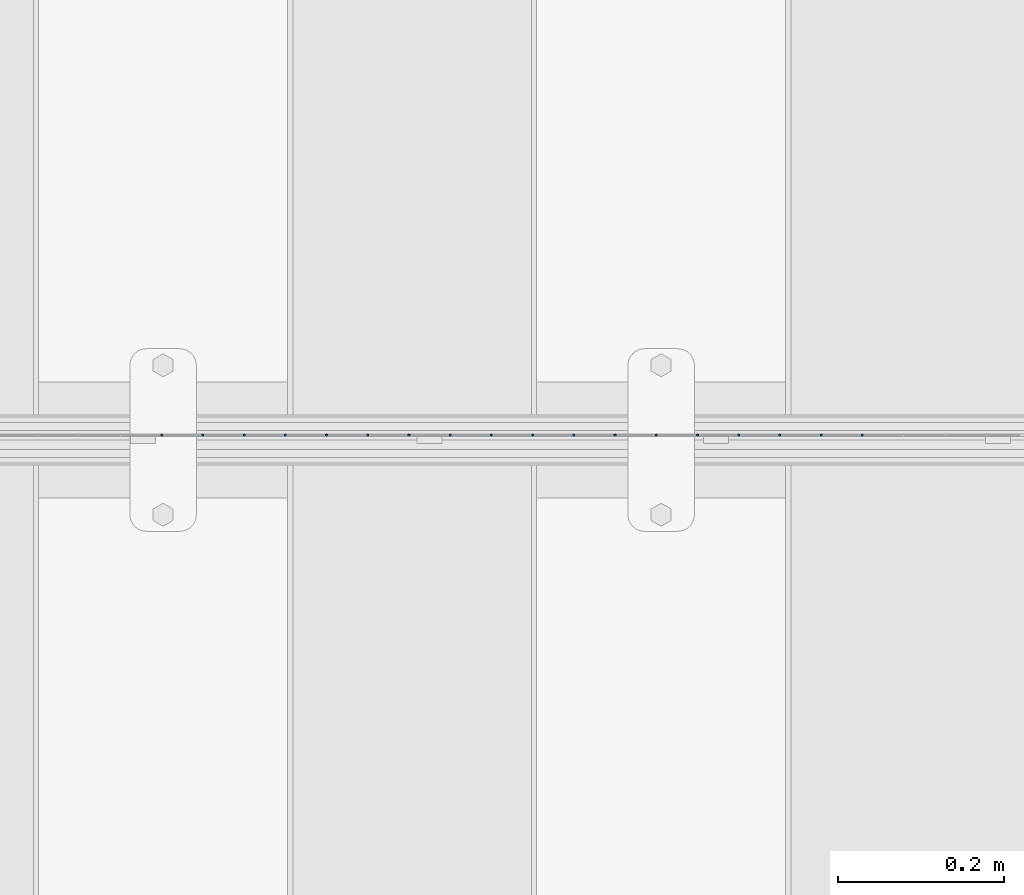
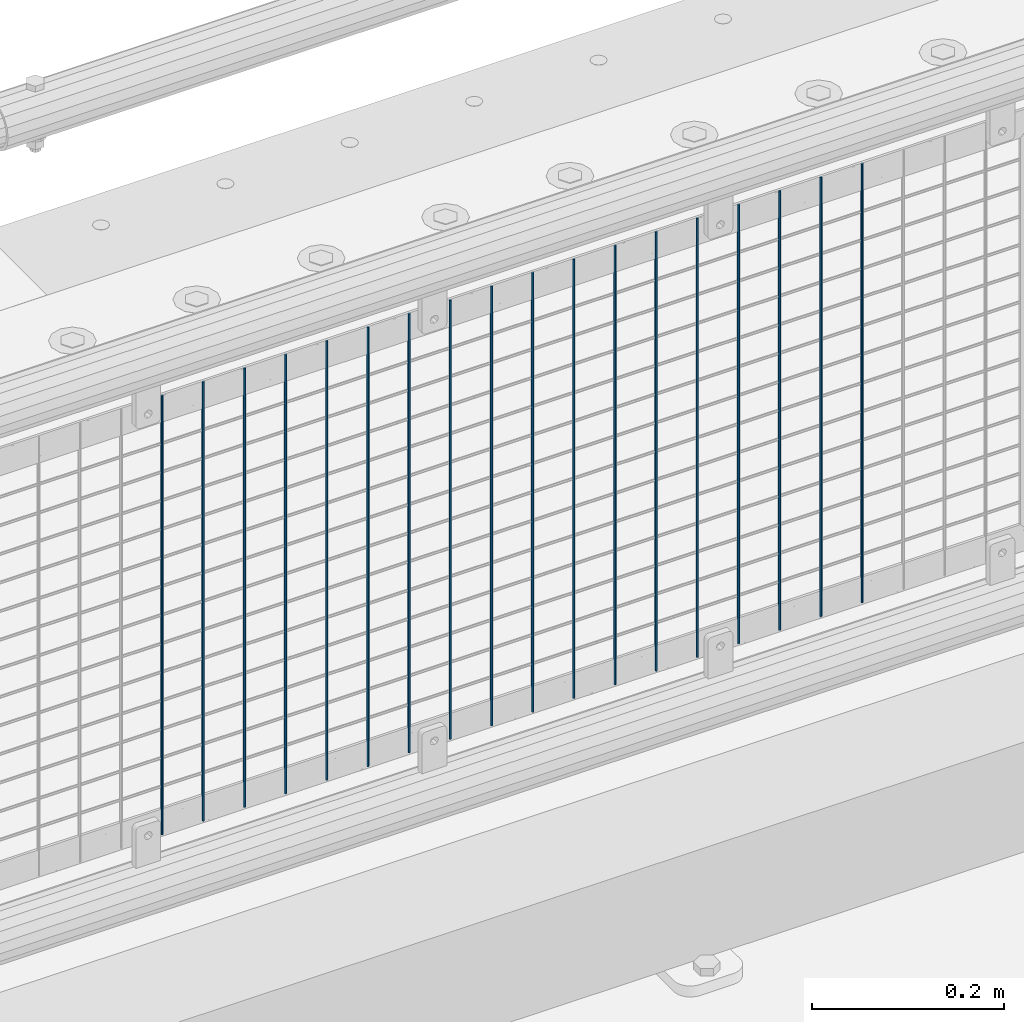
# One storey, part 72 of 208: 18 columns.
"""IFC2X3 building model written with IfcOpenShell, lengths in millimetres."""

from ifc_helpers import new_model, si_unit, frame, origin_with_axes, place, context, subcontext, project, spatial, faceted_brep, material, type_object, element, save


model = new_model("IFC2X3")

# Units and contexts
model_context = context("Model", 3, precision=1e-05, world=origin_with_axes())
body_context = subcontext(model_context, "Body", "Model", "MODEL_VIEW")
ifc_project = project(units=[si_unit("LENGTHUNIT", "METRE", prefix="MILLI"), si_unit("AREAUNIT", "SQUARE_METRE"), si_unit("VOLUMEUNIT", "CUBIC_METRE"), si_unit("MASSUNIT", "GRAM", prefix="KILO"), si_unit("TIMEUNIT", "SECOND"), si_unit("PLANEANGLEUNIT", "RADIAN"), si_unit("SOLIDANGLEUNIT", "STERADIAN"), si_unit("THERMODYNAMICTEMPERATUREUNIT", "DEGREE_CELSIUS"), si_unit("LUMINOUSINTENSITYUNIT", "LUMEN")], contexts=[model_context])

# Site, building, storey
site_placement = place(None, origin_with_axes())
site = spatial("IfcSite", under=ifc_project, at=site_placement, CompositionType="ELEMENT")
building_placement = place(site_placement, origin_with_axes())
building = spatial("IfcBuilding", under=site, at=building_placement, Name="Standard", CompositionType="ELEMENT")
storey_placement = place(building_placement, origin_with_axes())
storey = spatial("IfcBuildingStorey", under=building, at=storey_placement, Name="Undefined", CompositionType="ELEMENT", Elevation=0.0)

# Columns
ifc_material = material(Name="Misc_Undefined")
column_type = type_object("IfcColumnType", Name="D3", PredefinedType="NOTDEFINED")
for number, where, z_axis, x_axis in (
    (1, (-32507.625, 4670.50000000001, 353.020000000003), (-1.0, 0.0, 0.0), (0.0, 0.0, 1.0)),
    (2, (-32557.28, 4670.50000000001, 353.020000000003), (-1.0, 0.0, 0.0), (0.0, 0.0, 1.0)),
    (3, (-32606.935, 4670.50000000001, 353.020000000003), (-1.0, 0.0, 0.0), (0.0, 0.0, 1.0)),
    (4, (-32656.59, 4670.50000000001, 353.020000000003), (-1.0, 0.0, 0.0), (0.0, 0.0, 1.0)),
    (5, (-32706.245, 4670.50000000001, 353.020000000003), (-1.0, 0.0, 0.0), (0.0, 0.0, 1.0)),
    (6, (-32755.9, 4670.50000000001, 353.020000000003), (-1.0, 0.0, 0.0), (0.0, 0.0, 1.0)),
    (7, (-32805.555, 4670.50000000001, 353.020000000003), (-1.0, 0.0, 0.0), (0.0, 0.0, 1.0)),
    (8, (-32855.21, 4670.50000000001, 353.020000000003), (-1.0, 0.0, 0.0), (0.0, 0.0, 1.0)),
    (9, (-32904.865, 4670.50000000001, 353.020000000003), (-1.0, 0.0, 0.0), (0.0, 0.0, 1.0)),
    (10, (-32954.52, 4670.50000000001, 353.020000000003), (-1.0, 0.0, 0.0), (0.0, 0.0, 1.0)),
    (11, (-33004.175, 4670.50000000001, 353.020000000003), (-1.0, 0.0, 0.0), (0.0, 0.0, 1.0)),
    (12, (-33053.83, 4670.50000000001, 353.020000000003), (-1.0, 0.0, 0.0), (0.0, 0.0, 1.0)),
    (13, (-33103.485, 4670.50000000001, 353.020000000003), (-1.0, 0.0, 0.0), (0.0, 0.0, 1.0)),
    (14, (-33153.14, 4670.50000000001, 353.020000000003), (-1.0, 0.0, 0.0), (0.0, 0.0, 1.0)),
    (15, (-33202.795, 4670.50000000001, 353.020000000003), (-1.0, 0.0, 0.0), (0.0, 0.0, 1.0)),
    (16, (-33252.45, 4670.5, 353.020000000003), (-1.0, 0.0, 0.0), (0.0, 0.0, 1.0)),
    (17, (-33302.105, 4670.5, 353.020000000003), (-1.0, 0.0, 0.0), (0.0, 0.0, 1.0)),
    (18, (-33351.76, 4670.5, 353.020000000003), (-1.0, 0.0, 0.0), (0.0, 0.0, 1.0)),
):
    element("IfcColumn", number, at=place(storey_placement, frame(where, z_axis=z_axis, x_axis=x_axis)), inside=storey, type_object=column_type, material=ifc_material, ObjectType="D3", context=body_context, shape_type="Brep", body=[
        faceted_brep([(0.0, -1.49999999999909, 3.63797880709171e-12), (-7.27595761418343e-12, -0.749999999999091, -1.29903810567669), (560.0, -0.75, -1.29903810567703), (560.0, -1.5, 0.0), (-3.63797880709171e-12, 0.750000000000909, -1.29903810567669), (560.0, 0.75, -1.29903810567703), (0.0, 1.50000000000182, 3.63797880709171e-12), (560.0, 1.5, 0.0), (-3.63797880709171e-12, 0.750000000000909, 1.29903810567669), (560.0, 0.75, 1.29903810567703), (-7.27595761418343e-12, -0.749999999999091, 1.29903810567669), (560.0, -0.75, 1.29903810567703)], [[[0, 1, 2, 3]], [[1, 4, 5, 2]], [[4, 6, 7, 5]], [[6, 8, 9, 7]], [[8, 10, 11, 9]], [[10, 0, 3, 11]], [[5, 7, 9, 11, 3, 2]], [[10, 8, 6, 4, 1, 0]]]),
    ])

save(model, "model.ifc")
